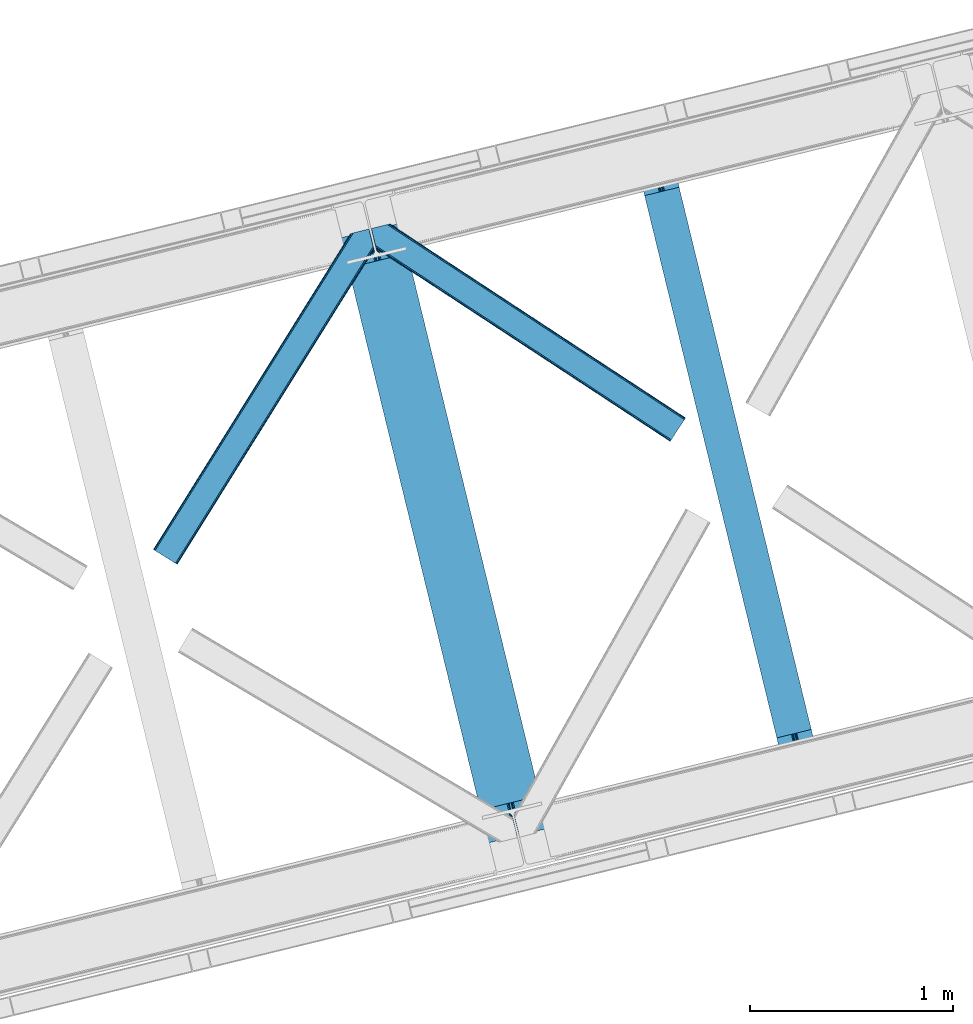
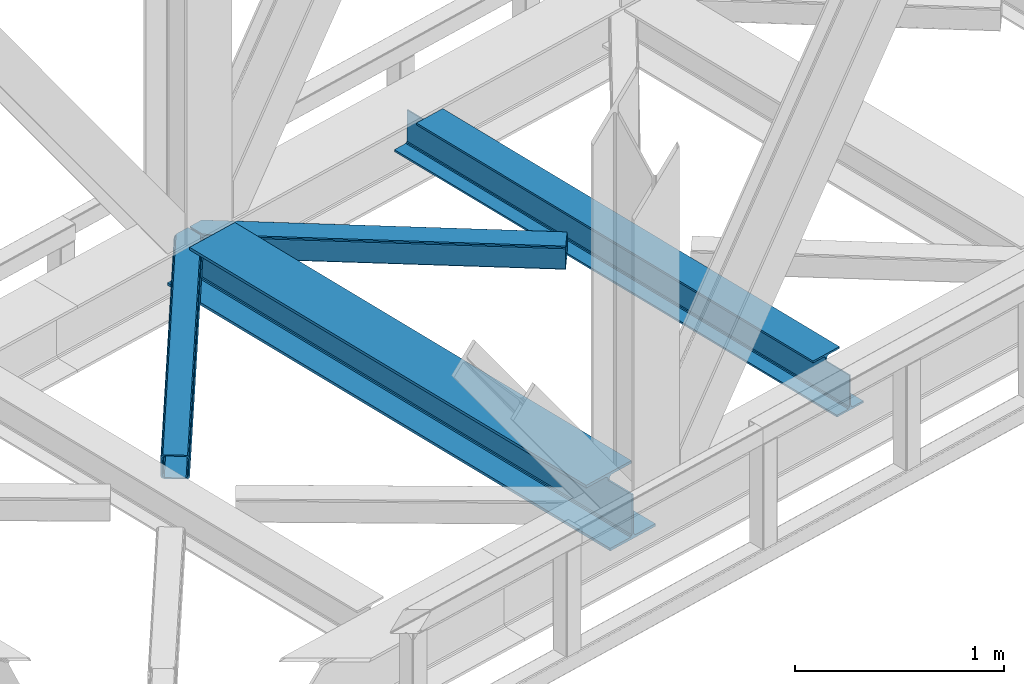
# One storey, part 76 of 93: 2 beams, 2 members.
"""IFC4 building model written with IfcOpenShell, lengths in millimetres."""

import ifcopenshell
import ifcopenshell.guid

model = None  # the IFC model being written
_history = None  # IfcOwnerHistory: only IFC2X3 demands one
_inside = {}  # id of a spatial element -> (the spatial element, [elements in it])
_under = {}  # id of a project, library or spatial element -> (it, [spatial elements below it])
_declared = {}  # id of a project -> (the project, [libraries it declares])
_typed = {}  # id of a type object -> (the type object, [elements of that type])
_made_of = {}  # id of a material, layer set ... -> (it, [elements and type objects made of it])


def new_model(schema):
    """Start an empty IFC model of exactly this schema.

    Asked for "IFC4X3", IfcOpenShell would pick the latest addendum, in which some entities
    have other attributes; the version numbers below select the first issue.
    IFC2X3 requires an IfcOwnerHistory on every rooted entity: one is made here for all.
    """
    global model, _history
    if schema == "IFC4X3":
        model = ifcopenshell.file(schema_version=(4, 3, 0, 0))
    else:
        model = ifcopenshell.file(schema=schema)
    _inside.clear()
    _under.clear()
    _declared.clear()
    _typed.clear()
    _made_of.clear()
    _history = None
    if model.schema == "IFC2X3":
        org = make("IfcOrganization", Name="unknown")
        user = make(
            "IfcPersonAndOrganization",
            ThePerson=make("IfcPerson", FamilyName="unknown"),
            TheOrganization=org,
        )
        app = make(
            "IfcApplication",
            ApplicationDeveloper=org,
            Version="unknown",
            ApplicationFullName="unknown",
            ApplicationIdentifier="unknown",
        )
        _history = make(
            "IfcOwnerHistory",
            OwningUser=user,
            OwningApplication=app,
            ChangeAction="ADDED",
            CreationDate=0,
        )
    return model


def make(cls, **values):
    """One entity of the class cls with the attributes given. An attribute that is None is left unset."""
    return model.create_entity(
        cls, **{name: value for name, value in values.items() if value is not None}
    )


def entity(cls, *values):
    """Any entity or typed value of the class cls, its attributes in the order of the schema. None: left unset."""
    e = model.create_entity(cls)
    for i, value in enumerate(values):
        if value is not None:
            e[i] = value
    return e


def rooted(cls, **values):
    """An entity with a GlobalId (a new one), such as an element, a storey or a relation."""
    return make(cls, GlobalId=ifcopenshell.guid.new(), OwnerHistory=_history, **values)


def si_unit(unit_type, name, prefix=None):
    """IfcSIUnit, for example si_unit("LENGTHUNIT", "METRE", prefix="MILLI")."""
    return make("IfcSIUnit", UnitType=unit_type, Prefix=prefix, Name=name)


def converted_unit(unit_type, name, factor, base, dimensions=None, offset=None):
    """IfcConversionBasedUnit, such as the inch: factor (a typed value) times the base unit."""
    return make(
        "IfcConversionBasedUnit"
        if offset is None
        else "IfcConversionBasedUnitWithOffset",
        ConversionOffset=offset,
        Dimensions=None
        if dimensions is None
        else entity("IfcDimensionalExponents", *dimensions),
        UnitType=unit_type,
        Name=name,
        ConversionFactor=make(
            "IfcMeasureWithUnit", ValueComponent=factor, UnitComponent=base
        ),
    )


def derived_unit(unit_type, elements):
    """IfcDerivedUnit: a product of units, each with its exponent."""
    return make(
        "IfcDerivedUnit",
        Elements=[
            make("IfcDerivedUnitElement", Unit=unit, Exponent=power)
            for unit, power in elements
        ],
        UnitType=unit_type,
    )


def assignment(units):
    """IfcUnitAssignment: the units of a project."""
    return None if units is None else make("IfcUnitAssignment", Units=units)


def point(xyz):
    """IfcCartesianPoint."""
    return None if xyz is None else make("IfcCartesianPoint", Coordinates=xyz)


def direction(xyz):
    """IfcDirection."""
    return None if xyz is None else make("IfcDirection", DirectionRatios=xyz)


def frame(location, z_axis=None, x_axis=None):
    """IfcAxis2Placement3D, a coordinate frame: its origin and axes. An axis left out is left unset."""
    return make(
        "IfcAxis2Placement3D",
        Location=point(location),
        Axis=direction(z_axis),
        RefDirection=direction(x_axis),
    )


def origin():
    """The frame at (0, 0, 0) with its axes left unset."""
    return frame((0.0, 0.0, 0.0))


def place(relative_to, where):
    """IfcLocalPlacement: puts the frame where relative to a parent placement (None: the world)."""
    return make(
        "IfcLocalPlacement", PlacementRelTo=relative_to, RelativePlacement=where
    )


def context(
    kind, dimensions, precision=None, world=None, true_north=None, identifier=None
):
    """IfcGeometricRepresentationContext, for example the 3D "Model" context."""
    return make(
        "IfcGeometricRepresentationContext",
        ContextIdentifier=identifier,
        ContextType=kind,
        CoordinateSpaceDimension=dimensions,
        Precision=precision,
        WorldCoordinateSystem=world,
        TrueNorth=true_north,
    )


def subcontext(parent, identifier, kind, view, scale=None):
    """IfcGeometricRepresentationSubContext, for example "Body" below "Model"."""
    return make(
        "IfcGeometricRepresentationSubContext",
        ContextIdentifier=identifier,
        ContextType=kind,
        ParentContext=parent,
        TargetScale=scale,
        TargetView=view,
    )


def project(units=None, contexts=None):
    """IfcProject with its units and contexts."""
    return rooted(
        "IfcProject",
        Name="project",
        RepresentationContexts=contexts,
        UnitsInContext=assignment(units),
    )


def spatial(cls, under=None, at=None, **own):
    """A site, building, storey or space (cls), placed at a placement, below another one or the project."""
    s = rooted(cls, ObjectPlacement=at, **own)
    if under is not None:
        _under.setdefault(under.id(), (under, []))[1].append(s)
    return s


def point_list(points):
    """IfcCartesianPointList2D or 3D."""
    cls = (
        "IfcCartesianPointList2D" if len(points[0]) == 2 else "IfcCartesianPointList3D"
    )
    return make(cls, CoordList=points)


def triangles(points, corners, closed=None, point_numbers=None):
    """IfcTriangulatedFaceSet: each triangle names its three corners, points numbered from 1."""
    return make(
        "IfcTriangulatedFaceSet",
        Coordinates=point_list(points),
        Closed=closed,
        CoordIndex=corners,
        PnIndex=point_numbers,
    )


def polygons(points, faces, closed=None, point_numbers=None):
    """IfcPolygonalFaceSet: a face is its outer loop, then its inner loops; points numbered from 1."""
    made = []
    for loops in faces:
        if len(loops) == 1:
            made.append(make("IfcIndexedPolygonalFace", CoordIndex=loops[0]))
        else:
            made.append(
                make(
                    "IfcIndexedPolygonalFaceWithVoids",
                    CoordIndex=loops[0],
                    InnerCoordIndices=loops[1:],
                )
            )
    return make(
        "IfcPolygonalFaceSet",
        Coordinates=point_list(points),
        Closed=closed,
        Faces=made,
        PnIndex=point_numbers,
    )


def shape(context_of_items, identifier, shape_type, items):
    """IfcShapeRepresentation: the items that make up one representation, for example the "Body"."""
    return make(
        "IfcShapeRepresentation",
        ContextOfItems=context_of_items,
        RepresentationIdentifier=identifier,
        RepresentationType=shape_type,
        Items=items,
    )


def material(Name=None, Category=None):
    """IfcMaterial."""
    return make("IfcMaterial", Name=Name, Category=Category)


def made_of(thing, what):
    """Note that an element or type object is made of a material, layer set ...; save() writes the relation."""
    if what is not None:
        _made_of.setdefault(what.id(), (what, []))[1].append(thing)
    return thing


def type_object(cls, material=None, **own):
    """A type object (cls), such as IfcWallType, which elements share."""
    return made_of(rooted(cls, **own), material)


def element(
    cls,
    number,
    at=None,
    inside=None,
    cuts=None,
    type_object=None,
    material=None,
    context=None,
    identifier="Body",
    shape_type=None,
    held_by="IfcProductDefinitionShape",
    body=None,
    shapes=None,
    **own,
):
    """One element of the class cls, such as IfcWall. Its Tag is "e" and its number.

    at: its placement. inside: the storey or other place that contains it. cuts: it is an
    opening in that element (IfcRelVoidsElement). A single representation is given by context,
    identifier, shape_type and body (its items); several are given by shapes. held_by: the class
    of the entity that holds the representations. save() writes the other relations.
    """
    e = rooted(cls, Tag="e%d" % number, ObjectPlacement=at, **own)
    if body is not None:
        shapes = [shape(context, identifier, shape_type, body)]
    if shapes is not None:
        e.Representation = make(held_by, Representations=shapes)
    if inside is not None:
        _inside.setdefault(inside.id(), (inside, []))[1].append(e)
    if cuts is not None:
        rooted(
            "IfcRelVoidsElement", RelatingBuildingElement=cuts, RelatedOpeningElement=e
        )
    if type_object is not None:
        _typed.setdefault(type_object.id(), (type_object, []))[1].append(e)
    return made_of(e, material)


def aggregate(whole, parts):
    """IfcRelAggregates: a whole, such as a stair, and the parts it consists of."""
    return rooted("IfcRelAggregates", RelatingObject=whole, RelatedObjects=parts)


def save(model, path):
    """Write the relations noted so far, then the file.

    IfcRelAggregates (storeys below a building ...), IfcRelContainedInSpatialStructure (elements
    in a storey), IfcRelDefinesByType, IfcRelAssociatesMaterial and IfcRelDeclares: one each for
    every whole, place, type object, material and project.
    """
    for whole, parts in _under.values():
        aggregate(whole, parts)
    for where, things in _inside.values():
        rooted(
            "IfcRelContainedInSpatialStructure",
            RelatedElements=things,
            RelatingStructure=where,
        )
    for kind, things in _typed.values():
        rooted("IfcRelDefinesByType", RelatedObjects=things, RelatingType=kind)
    for what, things in _made_of.values():
        rooted("IfcRelAssociatesMaterial", RelatedObjects=things, RelatingMaterial=what)
    for by, libraries in _declared.values():
        rooted("IfcRelDeclares", RelatingContext=by, RelatedDefinitions=libraries)
    model.write(path)


model = new_model("IFC4")

# Units and contexts
model_context = context("Model", 3, precision=0.01, world=origin(), true_north=direction((6.12303176911189e-17, 1.0)))
plan_context = context("Plan", 3, precision=0.01, world=origin(), true_north=direction((6.12303176911189e-17, 1.0)))
body_context = subcontext(model_context, "Body", "Model", "MODEL_VIEW")
ifc_project = project(units=[si_unit("LENGTHUNIT", "METRE", prefix="MILLI"), si_unit("AREAUNIT", "SQUARE_METRE"), si_unit("VOLUMEUNIT", "CUBIC_METRE"), converted_unit("PLANEANGLEUNIT", "DEGREE", entity("IfcRatioMeasure", 0.0174532925199433), si_unit("PLANEANGLEUNIT", "RADIAN"), dimensions=[0, 0, 0, 0, 0, 0, 0]), si_unit("MASSUNIT", "GRAM", prefix="KILO"), derived_unit("MASSDENSITYUNIT", [(si_unit("MASSUNIT", "GRAM", prefix="KILO"), 1), (si_unit("LENGTHUNIT", "METRE"), -3)]), derived_unit("MOMENTOFINERTIAUNIT", [(si_unit("LENGTHUNIT", "METRE"), 4)]), si_unit("TIMEUNIT", "SECOND"), si_unit("FREQUENCYUNIT", "HERTZ"), si_unit("THERMODYNAMICTEMPERATUREUNIT", "DEGREE_CELSIUS"), derived_unit("THERMALTRANSMITTANCEUNIT", [(si_unit("MASSUNIT", "GRAM", prefix="KILO"), 1), (si_unit("THERMODYNAMICTEMPERATUREUNIT", "KELVIN"), -1), (si_unit("TIMEUNIT", "SECOND"), -3)]), derived_unit("VOLUMETRICFLOWRATEUNIT", [(si_unit("LENGTHUNIT", "METRE"), 3), (si_unit("TIMEUNIT", "SECOND"), -1)]), derived_unit("MASSFLOWRATEUNIT", [(si_unit("MASSUNIT", "GRAM", prefix="KILO"), 1), (si_unit("TIMEUNIT", "SECOND"), -1)]), derived_unit("ROTATIONALFREQUENCYUNIT", [(si_unit("TIMEUNIT", "SECOND"), -1)]), si_unit("ELECTRICCURRENTUNIT", "AMPERE"), si_unit("ELECTRICVOLTAGEUNIT", "VOLT"), si_unit("POWERUNIT", "WATT"), si_unit("FORCEUNIT", "NEWTON", prefix="KILO"), si_unit("ILLUMINANCEUNIT", "LUX"), si_unit("LUMINOUSFLUXUNIT", "LUMEN"), si_unit("LUMINOUSINTENSITYUNIT", "CANDELA"), derived_unit("USERDEFINED", [(si_unit("MASSUNIT", "GRAM", prefix="KILO"), -1), (si_unit("LENGTHUNIT", "METRE"), -2), (si_unit("TIMEUNIT", "SECOND"), 3), (si_unit("LUMINOUSFLUXUNIT", "LUMEN"), 1)]), derived_unit("LINEARVELOCITYUNIT", [(si_unit("LENGTHUNIT", "METRE"), 1), (si_unit("TIMEUNIT", "SECOND"), -1)]), si_unit("PRESSUREUNIT", "PASCAL"), derived_unit("USERDEFINED", [(si_unit("LENGTHUNIT", "METRE"), -2), (si_unit("MASSUNIT", "GRAM", prefix="KILO"), 1), (si_unit("TIMEUNIT", "SECOND"), -2)]), derived_unit("LINEARFORCEUNIT", [(si_unit("MASSUNIT", "GRAM", prefix="KILO"), 1), (si_unit("LENGTHUNIT", "METRE"), 1), (si_unit("TIMEUNIT", "SECOND"), -2), (si_unit("LENGTHUNIT", "METRE"), -1)]), derived_unit("PLANARFORCEUNIT", [(si_unit("MASSUNIT", "GRAM", prefix="KILO"), 1), (si_unit("LENGTHUNIT", "METRE"), 1), (si_unit("TIMEUNIT", "SECOND"), -2), (si_unit("LENGTHUNIT", "METRE"), -2)])], contexts=[model_context, plan_context])

# Site, building, storey
site_placement = place(None, origin())
site = spatial("IfcSite", under=ifc_project, at=site_placement, CompositionType="ELEMENT")
building_placement = place(site_placement, origin())
building = spatial("IfcBuilding", under=site, at=building_placement, CompositionType="ELEMENT")
storey_placement = place(building_placement, frame((0.0, 0.0, 15900.0)))
storey = spatial("IfcBuildingStorey", under=building, at=storey_placement, CompositionType="ELEMENT", Elevation=15900.0)

# Beams
ifc_material = material(Name="Metal painted (White)")
beam_type = type_object("IfcBeamType", PredefinedType="BEAM")
beam_1_placement = place(storey_placement, frame((-11884.4026274507, 14897.9803377072, 3385.0)))
element("IfcBeam", 1, at=beam_1_placement, inside=storey, type_object=beam_type, material=ifc_material, ObjectType="Steel Beam", PredefinedType="BEAM", context=body_context, shape_type="Tessellation", body=[
    polygons([(1018.1664837833, 71.0478278971021, 15.4999999999986), (1018.1664837833, 71.0478278971021, 0.0), (291.465617442446, 3052.25531830421, 0.0), (291.465617442448, 3052.25531830421, 15.4999999999986), (894.779372399325, 40.970914087327, 15.4999999999986), (168.078506058474, 3022.17840449444, 15.4999999999986), (888.087028625373, 39.3395844888265, 16.8701684147941), (161.386162284522, 3020.54707489594, 16.8701684147941), (882.413533524757, 37.956610033654, 20.7720779386413), (155.712667183906, 3019.16410044077, 20.7720779386413), (878.622625296178, 37.0325360459184, 26.6116982174294), (151.921758955329, 3018.24002645303, 26.6116982174294), (877.291435352781, 36.7080444135029, 33.500000000001), (150.59056901193, 3017.91553482062, 33.500000000001), (140.875048430516, 3015.54727389071, 33.500000000001), (140.875048430518, 3015.54727389072, 259.000000000002), (150.590569011926, 3017.91553482062, 259.000000000002), (0.0, 2981.20749040711, 0.0), (0.0, 2981.20749040711, 15.4999999999986), (123.387111383964, 3011.28440421689, 15.4999999999986), (130.079455157922, 3012.91573381539, 16.8701684147963), (135.75295025854, 3014.29870827056, 20.7720779386413), (139.543858487119, 3015.2227822583, 26.6116982174294), (877.291435352779, 36.7080444135029, 259.000000000002), (867.575914771371, 34.3397834836014, 259.000000000002), (867.575914771369, 34.3397834836014, 33.500000000001), (866.24472482797, 34.0152918511859, 26.6116982174294), (862.453816599391, 33.0912178634502, 20.7720779386413), (856.780321498773, 31.70824340828, 16.8701684147963), (850.087977724817, 30.0769138097752, 15.4999999999986), (726.700866340853, 0.0, 15.4999999999986), (726.700866340851, 0.0, 0.0), (838.124523615903, 197.385937999177, 259.069791973884), (186.469722099962, 2870.72539801219, 259.000000000002), (186.693115201814, 2869.8089536072, 259.61730333112), (186.705504045441, 2869.75812937344, 266.500003008253), (837.979344808139, 197.981416001704, 266.500002998871), (837.979694928891, 197.97997969697, 260.000004007589), (828.499586345885, 194.645865944436, 259.006343171919), (828.276216326122, 195.562317481916, 259.61730333112), (828.263827482494, 195.613141715691, 266.500003008253), (176.989986719795, 2867.38985508742, 266.500002998871), (176.989636599043, 2867.39129139216, 260.000004007589), (176.844830940709, 2867.98534020595, 259.07612046749), (176.754201518552, 2868.35713708228, 259.000000000002), (839.310832678068, 198.30468544639, 273.388305639783), (843.101109266764, 199.231350618303, 279.227924098781), (848.774180214298, 200.616065081983, 283.129832400619), (855.466371895423, 202.248018612794, 284.500000377224), (978.853400583271, 232.325271667905, 284.500000138971), (978.85173077662, 232.332121736639, 299.999995328161), (687.386308679347, 161.283492472596, 299.999995890962), (687.387978485999, 161.276642403863, 284.500000701776), (810.775007173843, 191.353895458974, 284.500000463519), (817.467494069984, 192.984637925553, 283.129832461069), (823.141405718746, 194.365903570079, 279.227924137322), (826.93294050574, 195.287407219375, 273.388305663684), (175.658498849859, 2867.06658564273, 273.388305639783), (171.868222261163, 2866.13992047082, 279.227924098781), (166.195151313627, 2864.75520600715, 283.129832400619), (159.502959632495, 2863.12325247633, 284.500000377228), (36.1159309446555, 2833.04599942122, 284.500000138971), (36.117600751305, 2833.03914935249, 299.999995328161), (327.583022848578, 2904.08777861653, 299.999995890962), (327.58135304193, 2904.09462868526, 284.500000701776), (204.194324354075, 2874.01737563015, 284.500000463519), (197.501837457941, 2872.38663316357, 283.129832461069), (191.827925809183, 2871.00536751905, 279.227924137322), (188.036391022187, 2870.08386386975, 273.388305663684)], [[[1, 2, 3, 4]], [[5, 1, 4, 6]], [[7, 5, 6, 8]], [[9, 7, 8, 10]], [[11, 9, 10, 12]], [[13, 11, 12, 14]], [[15, 16, 17, 14, 12, 10, 8, 6, 4, 3, 18, 19, 20, 21, 22, 23]], [[13, 24, 25, 26, 27, 28, 29, 30, 31, 32, 2, 1, 5, 7, 9, 11]], [[2, 32, 18, 3]], [[32, 31, 19, 18]], [[31, 30, 20, 19]], [[27, 26, 15, 23]], [[28, 27, 23, 22]], [[29, 28, 22, 21]], [[30, 29, 21, 20]], [[33, 24, 13, 14, 17, 34, 35, 36, 37, 38]], [[25, 39, 40, 41, 42, 43, 44, 16, 15, 26]], [[39, 25, 24, 33]], [[45, 34, 17, 16]], [[41, 40, 38, 37, 46, 47, 48, 49, 50, 51, 52, 53, 54, 55, 56, 57]], [[42, 58, 59, 60, 61, 62, 63, 64, 65, 66, 67, 68, 69, 36, 35, 43]], [[46, 37, 36, 69]], [[47, 46, 69, 68]], [[48, 47, 68, 67]], [[49, 48, 67, 66]], [[50, 49, 66, 65]], [[51, 50, 65, 64]], [[52, 51, 64, 63]], [[53, 52, 63, 62]], [[54, 53, 62, 61]], [[55, 54, 61, 60]], [[56, 55, 60, 59]], [[57, 56, 59, 58]], [[41, 57, 58, 42]]], closed=False),
])
beam_2_placement = place(storey_placement, frame((-10424.6456600931, 15253.8115424252, 3441.0)))
element("IfcBeam", 2, at=beam_2_placement, inside=storey, type_object=beam_type, material=ifc_material, ObjectType="Steel Beam", PredefinedType="BEAM", context=body_context, shape_type="Tessellation", body=[
    polygons([(896.722476515612, 41.4445662733081, 11.000000000004), (896.722476515612, 41.4445662733081, 2.16573425859679e-12), (170.021610174759, 3022.65205668042, 2.16573425859679e-12), (170.021610174761, 3022.65205668042, 11.000000000004), (830.656936561991, 25.3403919499678, 11.000000000004), (103.956070221142, 3006.54788235708, 11.000000000004), (824.70818654069, 23.8903211957374, 12.2179274798217), (98.0073201998405, 3005.09781160285, 12.2179274798217), (819.665079784586, 22.6610105689194, 15.686291501017), (92.9642134437362, 3003.86850097603, 15.686291501017), (816.295383581404, 21.8396114687119, 20.8770650821657), (89.5945172405538, 3003.04710187582, 20.8770650821657), (815.112103631726, 21.5511744621206, 27.0000000000047), (88.4112372908744, 3002.75866486923, 27.0000000000047), (81.6103728838758, 3001.1008822183, 27.0000000000047), (81.6103728838779, 3001.1008822183, 203.000000000006), (88.4112372908766, 3002.75866486923, 203.000000000006), (2.16573425859679e-12, 2981.20749040711, 2.16573425859679e-12), (2.16573425859679e-12, 2981.20749040711, 10.9999999999997), (66.065539953615, 2997.31166473045, 11.000000000004), (72.0142899749205, 2998.76173548468, 12.2179274798217), (77.0573967310248, 2999.9910461115, 15.6862915010192), (80.4270929341964, 3000.81244521171, 20.8770650821657), (815.112103631729, 21.5511744621206, 203.000000000006), (808.31123922473, 19.8933918111876, 203.000000000006), (808.311239224726, 19.8933918111876, 27.0000000000047), (807.127959275046, 19.6049548045963, 20.8770650821657), (803.758263071877, 18.7835557043887, 15.6862915010192), (798.715156315772, 17.5542450775685, 12.2179274798217), (792.766406294465, 16.1041743233403, 11.000000000004), (726.700866340851, 0.0, 10.9999999999997), (726.700866340854, 0.0, 2.16573425859679e-12), (775.945201911954, 182.229070489523, 203.069792164282), (124.290390378911, 2855.5685280608, 203.000000000006), (124.513271168059, 2854.65418562637, 203.617301946336), (124.52618541258, 2854.60120565348, 217.000003693143), (775.79999866923, 182.824605273252, 217.000003676718), (775.800869277125, 182.821033832373, 204.00000679514), (769.234900758907, 180.199471824628, 203.006342981088), (769.012053092182, 181.113823838954, 203.617301946336), (768.999138847657, 181.166803811845, 217.000003693143), (117.725325591008, 2852.94340419208, 217.000003676718), (117.724454983115, 2852.94697563296, 204.00000679514), (117.580155394062, 2853.53894853353, 203.076120467494), (117.489525971921, 2853.91074540987, 203.000000000006), (776.983483393262, 183.112202246694, 223.122939328039), (780.352479801943, 183.936472070576, 228.313710402595), (785.395115205966, 185.167716295877, 231.782072735464), (791.343694076675, 186.618489150563, 232.999999602236), (857.409144942201, 202.723028934497, 232.999999283132), (857.40767160576, 202.729072911368, 243.999994005812), (687.386290701843, 161.283566114478, 243.999994827032), (687.38776403828, 161.277522137604, 233.000000104353), (753.453214903792, 177.382061921539, 232.999999785253), (759.402120032137, 178.831496389764, 231.782072861012), (764.445684539264, 180.058929212899, 228.313710479427), (767.816071449, 180.877494870328, 223.122939372324), (116.541840866975, 2852.65580721863, 223.122939328043), (113.172844458302, 2851.83153739476, 228.313710402595), (108.130209054278, 2850.60029316945, 231.782072735464), (102.181630183564, 2849.14952031477, 232.999999602236), (36.1161793180448, 2833.04498053083, 232.999999283128), (36.1176526544845, 2833.03893655396, 243.999994005812), (206.139033558403, 2874.48444335085, 243.999994827032), (206.137560221968, 2874.49048732773, 233.000000104357), (140.072109356447, 2858.38594754379, 232.999999785253), (134.12320422811, 2856.93651307556, 231.782072861012), (129.079639720982, 2855.70908025243, 228.313710479427), (125.709252811239, 2854.890514595, 223.12293937232)], [[[1, 2, 3, 4]], [[5, 1, 4, 6]], [[7, 5, 6, 8]], [[9, 7, 8, 10]], [[11, 9, 10, 12]], [[13, 11, 12, 14]], [[15, 16, 17, 14, 12, 10, 8, 6, 4, 3, 18, 19, 20, 21, 22, 23]], [[13, 24, 25, 26, 27, 28, 29, 30, 31, 32, 2, 1, 5, 7, 9, 11]], [[2, 32, 18, 3]], [[32, 31, 19, 18]], [[31, 30, 20, 19]], [[27, 26, 15, 23]], [[28, 27, 23, 22]], [[29, 28, 22, 21]], [[30, 29, 21, 20]], [[33, 24, 13, 14, 17, 34, 35, 36, 37, 38]], [[25, 39, 40, 41, 42, 43, 44, 16, 15, 26]], [[39, 25, 24, 33]], [[45, 34, 17, 16]], [[41, 40, 38, 37, 46, 47, 48, 49, 50, 51, 52, 53, 54, 55, 56, 57]], [[42, 58, 59, 60, 61, 62, 63, 64, 65, 66, 67, 68, 69, 36, 35, 43]], [[46, 37, 36, 69]], [[47, 46, 69, 68]], [[48, 47, 68, 67]], [[49, 48, 67, 66]], [[50, 49, 66, 65]], [[51, 50, 65, 64]], [[52, 51, 64, 63]], [[53, 52, 63, 62]], [[54, 53, 62, 61]], [[55, 54, 61, 60]], [[56, 55, 60, 59]], [[57, 56, 59, 58]], [[41, 57, 58, 42]]], closed=False),
])

# Members
member_type_1 = type_object("IfcMemberType", PredefinedType="BRACE")
member_1_placement = place(storey_placement, frame((-12809.6402069092, 16269.3394958496, 3510.00011901855)))
element("IfcMember", 3, at=member_1_placement, inside=storey, type_object=member_type_1, ObjectType="Steel Horizontal Brace", PredefinedType="BRACE", context=body_context, shape_type="Tessellation", body=[
    triangles([(933.019793701173, 1535.69114685059, 0.0), (967.779299926759, 1393.09054870606, 0.0), (14.8479309082031, 64.8692962646492, 0.0), (103.918075561523, 9.26687622070313, 0.0), (928.802609252929, 1552.99009094238, 5.49966430664063), (928.943298339844, 1552.41570739746, 5.20782165527635), (930.802487182616, 1544.78594055176, 1.33247680664135), (971.996484375, 1375.79160461426, 5.49966430664063), (971.856958007813, 1376.36598815918, 5.20782165527635), (969.996606445313, 1383.99575500488, 1.33247680664135), (972.211587524414, 1375.53696899414, 5.85313110351854), (972.422039794921, 1375.28233337402, 6.20659790039281), (928.915393066407, 1553.56912536621, 5.74383544921875), (972.724346923827, 1375.53696899414, 6.35310058594041), (929.030502319336, 1554.17606506348, 5.9996337890625), (973.025491333008, 1375.79160461426, 6.49960327148438), (929.145611572265, 1554.78300476074, 6.25659484863354), (929.253744506836, 1555.36087646485, 6.49960327148438), (4.3520599365238, 71.4223846435543, 5.12526855468968), (1.13365173339844, 73.4315643310547, 10.8028289794929), (973.359191894531, 1630.84231567383, 10.8028289794929), (976.915951538085, 1631.70854187012, 6.49960327148438), (9.16804504394531, 68.4155914306648, 1.33247680664135), (971.506979370117, 1630.3900177002, 17.5000946044929), (0.0, 74.1361724853523, 17.5000946044929), (1081.10028991699, 1548.91592102051, 6.49960327148438), (1056.20762329101, 1651.03643188476, 6.49960327148438), (971.506979370117, 1630.3900177002, 122.500662231447), (0.0, 74.1361724853523, 122.500662231447), (973.359191894531, 1630.84231567383, 129.197927856447), (1.13365173339844, 73.4315643310547, 129.197927856447), (978.636776733398, 1632.12828369141, 134.874325561526), (4.3520599365238, 71.4223846435543, 134.874325561526), (986.530480957032, 1634.05258483887, 138.667117309571), (9.16804504394531, 68.4155914306648, 138.667117309571), (995.83921508789, 1636.32105102539, 139.999594116212), (14.8479309082031, 64.8692962646492, 139.999594116212), (118.762518310547, 0.0, 17.5000946044929), (117.632354736328, 0.705770874023074, 10.8028289794929), (1085.14190368652, 1551.24949951172, 10.9783996582046), (1087.41618347168, 1552.56337280274, 13.5003387451179), (109.597961425781, 5.7205810546875, 1.33247680664135), (114.413946533203, 2.71378784179615, 5.12526855468968), (1087.56966247559, 1551.93434143066, 17.5000946044929), (1081.77583007812, 1575.70149536133, 139.999594116212), (1063.00837097168, 1652.69447021484, 139.999594116212), (103.918075561523, 9.26687622070313, 139.999594116212), (1083.99313659668, 1566.60553894043, 138.667117309571), (109.597961425781, 5.7205810546875, 138.667117309571), (1085.8720916748, 1558.8955444336, 134.874325561526), (114.413946533203, 2.71378784179615, 134.874325561526), (1087.12782897949, 1553.7435333252, 129.197927856447), (117.632354736328, 0.705770874023074, 129.197927856447), (1087.56966247559, 1551.93434143066, 122.500662231447), (118.762518310547, 0.0, 122.500662231447), (1082.53973693848, 1566.77297058106, 12.1260040283232), (1083.96406860352, 1566.72297363281, 13.5003387451179), (1077.85048828125, 1569.98440246582, 8.3320495605476), (1074.64952087402, 1577.50022277832, 6.99957275390625), (1056.69596557617, 1651.1561920166, 6.99957275390625), (1005.57234191895, 1638.6941619873, 6.99957275390625), (20.7836151123047, 61.1613830566403, 6.99957275390625), (97.9789031982418, 12.9736267089847, 6.99957275390625), (108.474774169921, 6.42053833007776, 12.1260040283232), (111.693182373047, 4.4113586425774, 17.8035644531265), (1084.81052856445, 1563.24992980957, 17.8035644531265), (103.6587890625, 9.42733154296911, 8.3320495605476), (1085.25236206055, 1561.44073791504, 24.4996673583992), (112.822183227539, 3.70675048828161, 24.4996673583992), (983.092318725587, 1633.21426391602, 17.8035644531265), (981.240106201172, 1632.76312866211, 24.4996673583992), (7.06817321777271, 69.7236511230476, 17.8035644531265), (5.93917236328161, 70.4294219970707, 24.4996673583992), (988.369903564453, 1634.50139465332, 12.1260040283232), (10.2865814208981, 67.7144714355472, 12.1260040283232), (996.263607788085, 1636.42569580078, 8.3320495605476), (15.1025665283196, 64.7088409423832, 8.3320495605476), (981.240106201172, 1632.76312866211, 115.501089477541), (5.93917236328161, 70.4294219970707, 115.501089477541), (996.263607788085, 1636.42569580078, 131.667544555665), (1005.57234191895, 1638.6941619873, 133.000021362306), (1063.00837097168, 1652.69447021484, 133.000021362306), (988.369903564453, 1634.50139465332, 127.87475280762), (983.092318725587, 1633.21426391602, 122.196029663086), (20.7836151123047, 61.1613830566403, 133.000021362306), (15.1025665283196, 64.7088409423832, 131.667544555665), (10.2865814208981, 67.7144714355472, 127.87475280762), (7.06817321777271, 69.7236511230476, 122.196029663086), (108.474774169921, 6.42053833007776, 127.87475280762), (111.693182373047, 4.4113586425774, 122.196029663086), (112.822183227539, 3.70675048828161, 115.501089477541), (97.9789031982418, 12.9736267089847, 133.000021362306), (103.6587890625, 9.42733154296911, 131.667544555665), (1085.25236206055, 1561.44073791504, 115.501089477541), (1084.81052856445, 1563.24992980957, 122.196029663086), (1083.55479125976, 1568.40194091797, 127.87475280762), (1081.67583618164, 1576.11309814453, 131.667544555665), (1079.45852966309, 1585.2078918457, 133.000021362306)], [[1, 2, 3], [4, 3, 2], [1, 5, 2], [6, 5, 1], [1, 7, 6], [2, 5, 8], [8, 9, 2], [10, 2, 9], [11, 8, 5], [12, 11, 13], [14, 12, 15], [16, 14, 17], [17, 18, 16], [15, 17, 14], [13, 15, 12], [5, 13, 11], [17, 19, 18], [19, 17, 15], [13, 19, 15], [19, 13, 5], [5, 6, 19], [20, 21, 18], [18, 19, 20], [21, 22, 18], [19, 6, 7], [7, 1, 23], [3, 23, 1], [7, 23, 19], [24, 21, 20], [20, 25, 24], [18, 26, 16], [26, 18, 22], [27, 26, 22], [28, 24, 29], [25, 29, 24], [30, 28, 31], [29, 31, 28], [32, 30, 33], [31, 33, 30], [34, 32, 35], [33, 35, 32], [36, 34, 37], [35, 37, 34], [38, 39, 40], [40, 41, 38], [42, 10, 9], [39, 12, 16], [16, 40, 39], [16, 26, 40], [9, 39, 43], [9, 12, 39], [9, 43, 42], [2, 10, 4], [42, 4, 10], [41, 44, 38], [45, 36, 37], [36, 45, 46], [37, 47, 45], [48, 45, 47], [47, 49, 48], [50, 48, 49], [49, 51, 50], [52, 50, 51], [51, 53, 52], [54, 52, 53], [53, 55, 54], [44, 54, 55], [55, 38, 44], [56, 40, 26], [41, 40, 56], [56, 57, 41], [58, 26, 59], [26, 58, 56], [60, 59, 26], [59, 61, 62], [61, 59, 60], [62, 63, 59], [64, 65, 66], [66, 57, 64], [58, 59, 63], [63, 67, 58], [56, 58, 67], [67, 64, 56], [57, 56, 64], [68, 66, 65], [65, 69, 68], [70, 71, 72], [73, 72, 71], [74, 70, 75], [72, 75, 70], [76, 74, 77], [75, 77, 74], [61, 76, 62], [77, 62, 76], [71, 78, 73], [79, 73, 78], [34, 36, 80], [46, 81, 36], [81, 46, 82], [81, 80, 36], [83, 34, 80], [83, 32, 34], [32, 84, 30], [84, 32, 83], [28, 84, 78], [84, 28, 30], [61, 22, 76], [70, 74, 22], [74, 76, 22], [61, 60, 22], [71, 70, 24], [21, 24, 70], [28, 71, 24], [71, 28, 78], [70, 22, 21], [80, 81, 85], [85, 86, 80], [83, 80, 86], [86, 87, 83], [84, 83, 87], [87, 88, 84], [78, 84, 88], [88, 79, 78], [53, 89, 90], [91, 38, 55], [53, 90, 55], [53, 51, 89], [90, 91, 55], [89, 51, 49], [92, 47, 37], [47, 93, 49], [93, 47, 92], [93, 89, 49], [39, 64, 43], [69, 38, 91], [38, 65, 39], [65, 38, 69], [39, 65, 64], [4, 63, 3], [42, 43, 64], [64, 67, 42], [67, 63, 4], [4, 42, 67], [87, 35, 33], [37, 85, 92], [37, 86, 85], [86, 37, 35], [87, 86, 35], [79, 29, 25], [31, 88, 87], [33, 31, 87], [88, 31, 29], [79, 88, 29], [23, 75, 19], [3, 63, 62], [62, 77, 3], [77, 75, 23], [23, 3, 77], [20, 19, 75], [25, 73, 79], [72, 25, 20], [25, 72, 73], [72, 20, 75], [66, 41, 57], [54, 44, 68], [44, 66, 68], [68, 94, 54], [44, 41, 66], [95, 54, 94], [52, 54, 95], [50, 95, 96], [95, 50, 52], [96, 48, 50], [97, 48, 96], [97, 98, 45], [97, 45, 48], [98, 46, 45], [98, 82, 46], [81, 98, 85], [81, 82, 98], [92, 85, 98], [95, 94, 90], [91, 90, 94], [96, 95, 89], [90, 89, 95], [97, 96, 93], [89, 93, 96], [98, 97, 92], [93, 92, 97], [94, 68, 91], [69, 91, 68]]),
])
member_type_2 = type_object("IfcMemberType", PredefinedType="BRACE")
member_2_placement = place(storey_placement, frame((-11734.9697570801, 16875.1013580322, 3510.00011901855)))
element("IfcMember", 4, at=member_2_placement, inside=storey, type_object=member_type_2, ObjectType="Steel Horizontal Brace", PredefinedType="BRACE", context=body_context, shape_type="Tessellation", body=[
    triangles([(1548.83336791992, 117.035879516599, 122.500662231447), (1548.83336791992, 117.035879516599, 17.5000946044929), (93.3036071777333, 1072.51941833496, 122.500662231447), (93.3036071777333, 1072.51941833496, 17.5000946044929), (1539.23046569824, 102.406539916992, 139.999594116212), (1542.90582275391, 108.005035400391, 138.667117309571), (78.9486694335938, 1069.01963195801, 138.667117309571), (70.0515380859379, 1066.85115966797, 139.999594116212), (1546.02423706055, 112.751257324217, 134.874325561526), (86.4947204589844, 1070.85905456543, 134.874325561526), (1548.10434265137, 115.921994018554, 129.197927856447), (91.5327850341801, 1072.0880493164, 129.197927856447), (18.1488922119133, 975.321862792967, 139.999594116212), (0.0, 1049.77545776367, 139.999594116212), (1481.61188964844, 14.6293395996072, 139.999594116212), (1472.00782470703, 0.0, 122.500662231447), (1472.73684997558, 1.11388549804542, 129.197927856447), (24.2241027832024, 950.400128173827, 122.500662231447), (23.7613403320302, 952.296524047852, 129.197927856447), (1474.82160644531, 4.28578491210646, 134.874325561526), (22.4439788818363, 957.699682617185, 134.874325561526), (1477.93536987305, 9.03084411620875, 138.667117309571), (20.4731689453129, 965.784072875977, 138.667117309571), (1472.00782470703, 0.0, 17.5000946044929), (24.2241027832024, 950.400128173827, 17.5000946044929), (1548.10434265137, 115.921994018554, 10.8028289794929), (91.1804809570313, 1072.00200805664, 10.8679412841811), (163.772561645508, 1023.9595916748, 9.52034912109593), (1546.02423706055, 112.751257324217, 5.12526855468968), (166.108465576172, 1018.59829101562, 5.12526855468968), (165.189916992187, 1022.36666564941, 8.52041015625218), (164.479495239257, 1023.16196594238, 9.02037963867406), (90.7467864990231, 1071.89620056152, 9.52034912109593), (1542.90582275391, 108.005035400391, 1.33247680664135), (168.079275512695, 1010.51273803711, 1.33247680664135), (1539.23046569824, 102.406539916992, 0.0), (170.40471496582, 1000.97611083984, 0.0), (198.048376464843, 887.571405029295, 0.0), (164.338806152344, 879.354464721677, 0.0), (1481.61188964844, 14.6293395996072, 0.0), (169.43733215332, 1003.19574279785, 9.13665161133031), (168.980383300781, 1004.20614624023, 9.44360961914208), (169.896606445313, 1002.17603759766, 8.82736816406396), (170.358206176757, 1001.166796875, 8.52041015625218), (72.7711395263668, 1067.51507263184, 9.52034912109593), (168.468786621093, 1004.69565124511, 9.52034912109593), (172.834799194336, 991.006951904295, 6.99957275390625), (198.048376464843, 887.571405029295, 6.99957275390625), (1539.0665222168, 102.153067016599, 8.3320495605476), (1542.18028564453, 106.899288940429, 12.1260040283232), (77.1906372070316, 1068.59175109863, 12.1260040283232), (1544.26504211426, 110.07118835449, 17.8035644531265), (82.2333526611328, 1069.82074584961, 17.8035644531265), (1544.99406738281, 111.183911132812, 24.4996673583992), (84.0041748046879, 1070.25327758789, 24.4996673583992), (1535.39116516113, 96.5545715332009, 6.99957275390625), (173.638238525391, 881.621768188474, 6.99957275390625), (1485.45119018555, 20.4813079833984, 6.99957275390625), (164.935281372071, 879.499804687497, 8.82504272460938), (161.614553833007, 878.690551757813, 9.52034912109593), (155.438186645508, 877.184829711914, 1.33247680664135), (147.892135620117, 875.345407104491, 5.12526855468968), (143.640069580078, 874.309423828123, 9.52034912109593), (30.6016204833977, 948.074688720702, 10.8702667236357), (24.2136383056641, 950.43966064453, 16.5199218750022), (1472.73684997558, 1.11388549804542, 10.8028289794929), (1474.82160644531, 4.28578491210646, 5.12526855468968), (32.1329223632802, 947.51076965332, 9.52034912109593), (1477.93536987305, 9.03084411620875, 1.33247680664135), (27.4366973876949, 966.774710083006, 9.52034912109593), (25.3949615478505, 964.131848144531, 12.1260040283232), (21.1254547119133, 963.109817504883, 16.5199218750022), (1476.5808013916, 6.96585388183303, 17.8035644531265), (1478.66090698242, 10.1365905761704, 12.1260040283232), (21.2382385253895, 962.647055053709, 17.8686767578147), (21.7940185546868, 960.368124389646, 24.4996673583992), (1481.77467041016, 14.8828125, 8.3320495605476), (1475.84712524414, 5.85196838378761, 24.4996673583992), (1544.99406738281, 111.183911132812, 115.501089477541), (84.0041748046879, 1070.25327758789, 115.501089477541), (77.1906372070316, 1068.59175109863, 127.87475280762), (69.6492370605465, 1066.75349121094, 131.667544555665), (82.2333526611328, 1069.82074584961, 122.196029663086), (60.7474548339833, 1064.58385620117, 133.000021362306), (0.0, 1049.77545776367, 133.000021362306), (1544.26504211426, 110.07118835449, 122.196029663086), (1542.18028564453, 106.899288940429, 127.87475280762), (1539.0665222168, 102.153067016599, 131.667544555665), (1535.39116516113, 96.5545715332009, 133.000021362306), (1478.66090698242, 10.1365905761704, 127.87475280762), (1485.45119018555, 20.4813079833984, 133.000021362306), (1481.77467041016, 14.8828125, 131.667544555665), (1475.84712524414, 5.85196838378761, 115.501089477541), (1476.5808013916, 6.96585388183303, 122.196029663086), (21.3312561035145, 962.265682983398, 122.196029663086), (20.0138946533207, 967.667678833008, 127.87475280762), (21.7940185546868, 960.368124389646, 115.501089477541), (18.0430847167972, 975.753231811523, 131.667544555665), (15.7188079833977, 985.289859008786, 133.000021362306)], [[1, 2, 3], [4, 3, 2], [5, 6, 7], [7, 8, 5], [6, 9, 10], [10, 7, 6], [9, 11, 12], [12, 10, 9], [11, 1, 3], [3, 12, 11], [8, 13, 5], [8, 14, 13], [15, 5, 13], [16, 17, 18], [19, 18, 17], [17, 20, 19], [21, 19, 20], [20, 22, 21], [23, 21, 22], [22, 15, 23], [13, 23, 15], [24, 16, 18], [18, 25, 24], [26, 27, 4], [27, 26, 28], [26, 29, 30], [30, 31, 26], [26, 31, 32], [32, 28, 26], [28, 33, 27], [29, 34, 35], [35, 30, 29], [34, 36, 37], [37, 35, 34], [4, 2, 26], [38, 37, 36], [39, 38, 40], [36, 40, 38], [32, 41, 42], [31, 43, 41], [31, 44, 43], [45, 33, 28], [28, 46, 45], [44, 35, 37], [30, 35, 44], [44, 31, 30], [47, 44, 37], [37, 38, 47], [48, 47, 38], [49, 44, 47], [43, 49, 41], [43, 44, 49], [42, 41, 49], [50, 51, 46], [46, 49, 50], [51, 45, 46], [50, 52, 53], [53, 51, 50], [52, 54, 55], [55, 53, 52], [47, 56, 49], [48, 57, 58], [47, 48, 56], [58, 56, 48], [59, 57, 39], [60, 39, 61], [61, 62, 60], [38, 57, 48], [57, 38, 39], [62, 63, 60], [39, 60, 59], [24, 25, 64], [25, 65, 64], [66, 64, 63], [63, 67, 66], [63, 62, 67], [64, 68, 63], [40, 69, 39], [61, 39, 69], [69, 67, 61], [62, 61, 67], [64, 66, 24], [70, 64, 71], [64, 70, 68], [65, 71, 64], [72, 71, 65], [68, 70, 60], [60, 63, 68], [73, 74, 71], [71, 72, 73], [73, 75, 76], [77, 58, 57], [74, 77, 59], [59, 60, 74], [74, 60, 71], [70, 71, 60], [57, 59, 77], [76, 78, 73], [72, 75, 73], [54, 79, 80], [80, 55, 54], [81, 82, 7], [10, 81, 7], [10, 12, 83], [81, 10, 83], [83, 12, 3], [82, 8, 7], [14, 84, 85], [14, 8, 84], [82, 84, 8], [83, 3, 80], [55, 4, 53], [3, 55, 80], [4, 27, 53], [3, 4, 55], [33, 53, 27], [51, 53, 33], [45, 51, 33], [79, 86, 80], [83, 80, 86], [86, 87, 83], [81, 83, 87], [87, 88, 81], [82, 81, 88], [88, 89, 82], [84, 82, 89], [11, 87, 86], [79, 2, 1], [11, 86, 1], [11, 9, 87], [86, 79, 1], [87, 9, 6], [89, 5, 15], [5, 88, 6], [88, 5, 89], [88, 87, 6], [26, 50, 29], [54, 2, 79], [2, 52, 26], [52, 2, 54], [26, 52, 50], [36, 56, 40], [34, 29, 50], [50, 49, 34], [49, 56, 36], [36, 34, 49], [90, 22, 20], [15, 91, 89], [15, 92, 91], [92, 15, 22], [90, 92, 22], [93, 16, 24], [17, 94, 90], [20, 17, 90], [94, 17, 16], [93, 94, 16], [69, 74, 67], [40, 56, 58], [58, 77, 40], [77, 74, 69], [69, 40, 77], [66, 67, 74], [24, 78, 93], [73, 24, 66], [24, 73, 78], [73, 66, 74], [95, 21, 96], [97, 76, 18], [19, 95, 18], [95, 19, 21], [95, 97, 18], [76, 25, 18], [75, 72, 65], [65, 25, 75], [76, 75, 25], [98, 23, 13], [14, 99, 13], [85, 99, 14], [98, 96, 23], [23, 96, 21], [99, 98, 13], [99, 84, 89], [84, 99, 85], [89, 91, 99], [91, 92, 98], [98, 99, 91], [92, 90, 96], [96, 98, 92], [90, 94, 95], [95, 96, 90], [94, 93, 97], [97, 95, 94], [93, 78, 76], [76, 97, 93]]),
])

save(model, "model.ifc")
